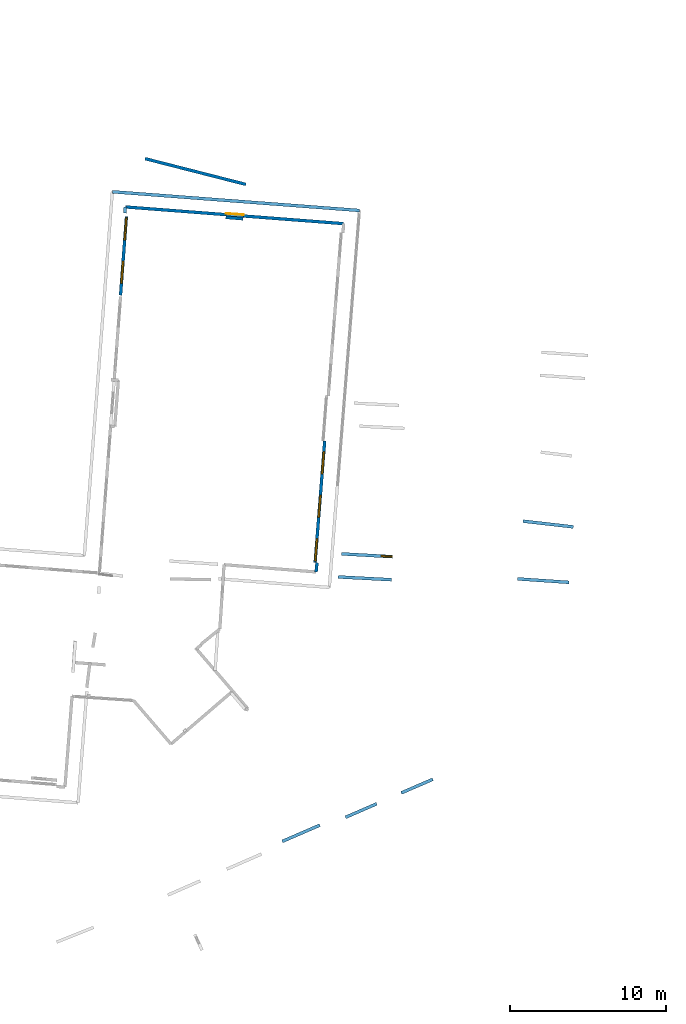
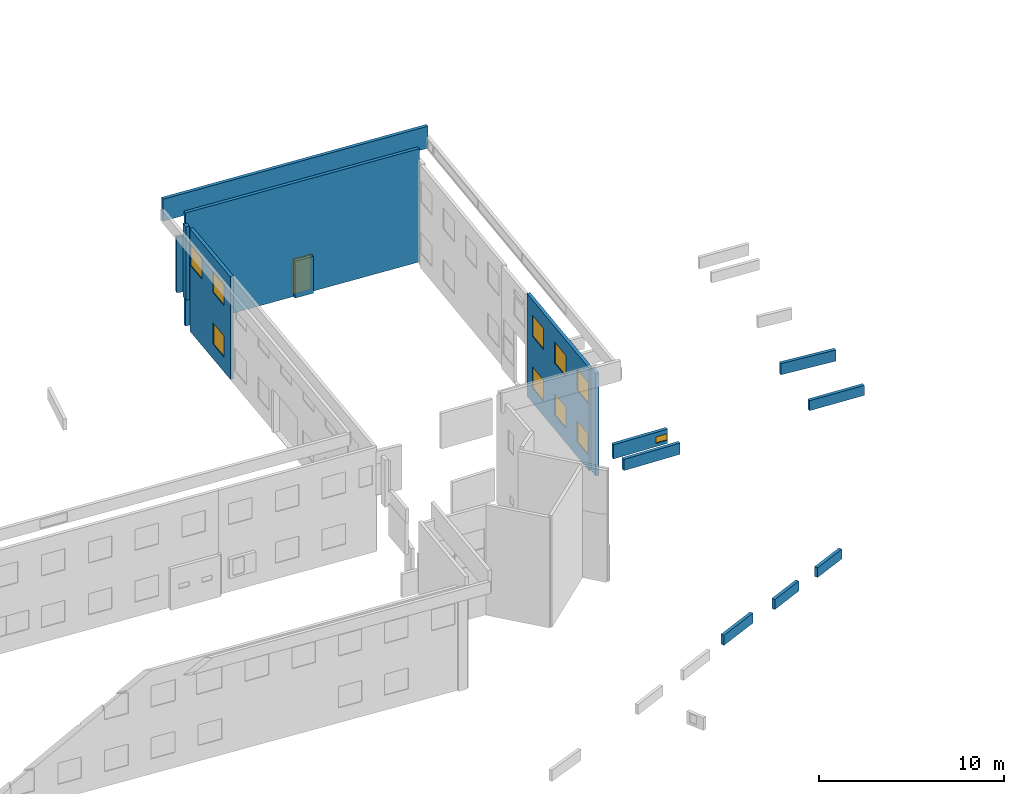
# One storey, part 23 of 27: 15 walls, 10 windows, 1 door, 11 openings.
"""IFC2X3 building model written with IfcOpenShell, lengths in metres."""

from ifc_helpers import new_model, entity, si_unit, converted_unit, derived_unit, direction, frame, frame_2d, origin, origin_2d_with_axis, place, context, subcontext, project, spatial, polyline, rectangle, outline, extrude, source, transform, mapped, material, layer, layer_set, layer_usage, type_object, type_shapes, element, fill, save


model = new_model("IFC2X3")

# Units and contexts
model_context = context("Model", 3, precision=1e-05, world=origin(), true_north=direction((0.0, 1.0)))
body_context = subcontext(model_context, "Body", "Model", "MODEL_VIEW")
ifc_project = project(units=[si_unit("LENGTHUNIT", "METRE"), si_unit("AREAUNIT", "SQUARE_METRE"), si_unit("VOLUMEUNIT", "CUBIC_METRE"), converted_unit("PLANEANGLEUNIT", "DEGREE", entity("IfcRatioMeasure", 0.0174532925199433), si_unit("PLANEANGLEUNIT", "RADIAN"), dimensions=[0, 0, 0, 0, 0, 0, 0]), si_unit("MASSUNIT", "GRAM", prefix="KILO"), derived_unit("MASSDENSITYUNIT", [(si_unit("MASSUNIT", "GRAM", prefix="KILO"), 1), (si_unit("LENGTHUNIT", "METRE"), -3)]), derived_unit("MOMENTOFINERTIAUNIT", [(si_unit("LENGTHUNIT", "METRE"), 4)]), si_unit("TIMEUNIT", "SECOND"), si_unit("FREQUENCYUNIT", "HERTZ"), si_unit("THERMODYNAMICTEMPERATUREUNIT", "DEGREE_CELSIUS"), derived_unit("THERMALTRANSMITTANCEUNIT", [(si_unit("MASSUNIT", "GRAM", prefix="KILO"), 1), (si_unit("THERMODYNAMICTEMPERATUREUNIT", "KELVIN"), -1), (si_unit("TIMEUNIT", "SECOND"), -3)]), derived_unit("VOLUMETRICFLOWRATEUNIT", [(si_unit("LENGTHUNIT", "METRE"), 3), (si_unit("TIMEUNIT", "SECOND"), -1)]), si_unit("ELECTRICCURRENTUNIT", "AMPERE"), si_unit("ELECTRICVOLTAGEUNIT", "VOLT"), si_unit("POWERUNIT", "WATT"), si_unit("FORCEUNIT", "NEWTON", prefix="KILO"), si_unit("ILLUMINANCEUNIT", "LUX"), si_unit("LUMINOUSFLUXUNIT", "LUMEN"), si_unit("LUMINOUSINTENSITYUNIT", "CANDELA"), derived_unit("USERDEFINED", [(si_unit("MASSUNIT", "GRAM", prefix="KILO"), -1), (si_unit("LENGTHUNIT", "METRE"), -2), (si_unit("TIMEUNIT", "SECOND"), 3), (si_unit("LUMINOUSFLUXUNIT", "LUMEN"), 1)]), derived_unit("LINEARVELOCITYUNIT", [(si_unit("LENGTHUNIT", "METRE"), 1), (si_unit("TIMEUNIT", "SECOND"), -1)]), si_unit("PRESSUREUNIT", "PASCAL"), derived_unit("USERDEFINED", [(si_unit("LENGTHUNIT", "METRE"), -2), (si_unit("MASSUNIT", "GRAM", prefix="KILO"), 1), (si_unit("TIMEUNIT", "SECOND"), -2)]), derived_unit("LINEARFORCEUNIT", [(si_unit("MASSUNIT", "GRAM", prefix="KILO"), 1), (si_unit("LENGTHUNIT", "METRE"), 1), (si_unit("TIMEUNIT", "SECOND"), -2), (si_unit("LENGTHUNIT", "METRE"), -1)]), derived_unit("PLANARFORCEUNIT", [(si_unit("MASSUNIT", "GRAM", prefix="KILO"), 1), (si_unit("LENGTHUNIT", "METRE"), 1), (si_unit("TIMEUNIT", "SECOND"), -2), (si_unit("LENGTHUNIT", "METRE"), -2)])], contexts=[model_context])

# Site, building, storey
placement_1 = place(None, origin())
site = spatial("IfcSite", under=ifc_project, at=placement_1, CompositionType="ELEMENT")
building = spatial("IfcBuilding", under=site, at=placement_1, CompositionType="ELEMENT")
storey_placement = place(placement_1, frame((0.0, 0.0, -61.043098449707)))
storey = spatial("IfcBuildingStorey", under=building, at=storey_placement, Name="level_-61.043098", CompositionType="ELEMENT", Elevation=-61.043098449707)

# Walls
ifc_material_1 = material(Name="Default wall")
ifc_layer = layer(ifc_material_1, 0.2)
ifc_layer_set = layer_set([ifc_layer], Name="wall_thickness_0.2000")
ifc_layer_usage = layer_usage(ifc_layer_set, "AXIS2", "POSITIVE", -0.1)
wall_type = type_object("IfcWallType", Name="wall_thickness_0.2000", PredefinedType="STANDARD", material=ifc_layer_set)
wall_1_placement = place(storey_placement, frame((18.2188514308673, -5.39371024535471, 0.0), z_axis=(0.0, 0.0, 1.0), x_axis=(0.0985031111427346, 0.995136742912853, 0.0)))
element("IfcWallStandardCase", 1, at=wall_1_placement, inside=storey, type_object=wall_type, material=ifc_layer_usage, Name="Wall:78", ObjectType="Wall", context=body_context, shape_type="SweptSolid", body=[
    extrude(outline(polyline([(0.596138961269039, -0.1), (0.596138961269039, 0.1), (0.0, 0.1), (0.0, -0.1), (0.596138961269039, -0.1)])), origin(), (0.0, 0.0, 1.0), 6.76219177246094),
])
placement_2 = place(placement_1, frame((0.0, 0.0, -60.9578857421875)))
wall_2_placement = place(placement_2, frame((20.1079442314191, -21.1138243418258, 0.0), z_axis=(0.0, 0.0, 1.0), x_axis=(0.917143584641455, 0.398556953459631, 0.0)))
element("IfcWallStandardCase", 2, at=wall_2_placement, inside=storey, type_object=wall_type, material=ifc_layer_usage, Name="Wall:220", ObjectType="Wall", context=body_context, shape_type="SweptSolid", body=[
    extrude(outline(polyline([(2.17951277879917, -0.1), (2.17951277879917, 0.1), (0.0, 0.1), (0.0, -0.1), (2.17951277879917, -0.1)])), origin(), (0.0, 0.0, 1.0), 0.661750793457031),
])

# Wall, opening, door
wall_3_placement = place(storey_placement, frame((5.99890342957978, 17.9934566983981, 0.0), z_axis=(0.0, 0.0, 1.0), x_axis=(0.997077459882406, -0.0763972446783893, 0.0)))
wall_3 = element("IfcWallStandardCase", 3, at=wall_3_placement, inside=storey, type_object=wall_type, material=ifc_layer_usage, Name="Wall:268", ObjectType="Wall", context=body_context, shape_type="SweptSolid", body=[
    extrude(outline(polyline([(14.0238372089625, -0.1), (14.0238372089625, 0.1), (0.0, 0.1), (0.0, -0.1), (14.0238372089625, -0.1)])), origin(), (0.0, 0.0, 1.0), 7.4647102355957),
])
opening_1_placement = place(wall_3_placement, frame((6.46277733357102, -0.1, 0.037811279296875)))
opening_1 = element("IfcOpeningElement", 4, at=opening_1_placement, cuts=wall_3, Name="Opening : 1140 x 2340 : 16", ObjectType="Opening", context=body_context, shape_type="SweptSolid", body=[
    extrude(rectangle(XDim=1.14, YDim=2.34, at=frame_2d((1.17, 0.57), x_axis=(0.0, 1.0))), frame((0.0, 0.0, 0.0), z_axis=(0.0, 1.0, 0.0), x_axis=(0.0, 0.0, 1.0)), (0.0, 0.0, 1.0), 0.2),
])
ifc_material_2 = material(Name="Door Panel")
door_style = type_object("IfcDoorStyle", Name="Door : 1140 x 2340mm", ConstructionType="NOTDEFINED", OperationType="SINGLE_SWING_RIGHT", ParameterTakesPrecedence=False, Sizeable=False, material=ifc_material_2)
shared_shape_1 = source(origin(), body_context, "Body", "SweptSolid", [
    extrude(rectangle(XDim=0.05, YDim=1.14, at=origin_2d_with_axis()), frame((0.57, 0.175, 0.0), z_axis=(0.0, 0.0, 1.0), x_axis=(0.0, 1.0, 0.0)), (0.0, 0.0, 1.0), 2.34),
])
type_shapes(door_style, [shared_shape_1])
door_placement = place(opening_1_placement, origin())
door = element("IfcDoor", 5, at=door_placement, inside=storey, type_object=door_style, Name="Door : 1140 x 2340mm : 2", ObjectType="Door : 1140 x 2340mm", OverallHeight=2.34, OverallWidth=1.14, context=body_context, shape_type="MappedRepresentation", body=[
    mapped(shared_shape_1, transform((0.0, 0.0, 0.0), scale=1.0)),
])
fill(opening_1, door)

# Wall, openings, windows
wall_4_placement = place(storey_placement, frame((18.7714172781975, 2.99446171995472, 0.0), z_axis=(0.0, 0.0, 1.0), x_axis=(-0.0787013877503453, -0.996898235310992, 0.0)))
wall_4 = element("IfcWallStandardCase", 6, at=wall_4_placement, inside=storey, type_object=wall_type, material=ifc_layer_usage, Name="Wall:297", ObjectType="Wall", context=body_context, shape_type="SweptSolid", body=[
    extrude(outline(polyline([(7.81068516129072, -0.1), (7.81068516129072, 0.1), (0.0, 0.1), (0.0, -0.1), (7.81068516129072, -0.1)])), origin(), (0.0, 0.0, 1.0), 6.76219177246094),
])
opening_2_placement = place(wall_4_placement, frame((0.694999373924037, -0.1, 4.37589645385742)))
opening_2 = element("IfcOpeningElement", 7, at=opening_2_placement, cuts=wall_4, Name="Opening : 1420 x 1390 : 17", ObjectType="Opening", context=body_context, shape_type="SweptSolid", body=[
    extrude(rectangle(XDim=1.42, YDim=1.39, at=frame_2d((0.695, 0.71), x_axis=(0.0, 1.0))), frame((0.0, 0.0, 0.0), z_axis=(0.0, 1.0, 0.0), x_axis=(0.0, 0.0, 1.0)), (0.0, 0.0, 1.0), 0.2),
])
opening_3_placement = place(wall_4_placement, frame((3.48999988778673, -0.1, 4.37089538574219)))
opening_3 = element("IfcOpeningElement", 8, at=opening_3_placement, cuts=wall_4, Name="Opening : 1420 x 1390 : 18", ObjectType="Opening", context=body_context, shape_type="SweptSolid", body=[
    extrude(rectangle(XDim=1.42, YDim=1.39, at=frame_2d((0.695, 0.71), x_axis=(0.0, 1.0))), frame((0.0, 0.0, 0.0), z_axis=(0.0, 1.0, 0.0), x_axis=(0.0, 0.0, 1.0)), (0.0, 0.0, 1.0), 0.2),
])
opening_4_placement = place(wall_4_placement, frame((6.29000000527762, -0.1, 4.36589813232422)))
opening_4 = element("IfcOpeningElement", 9, at=opening_4_placement, cuts=wall_4, Name="Opening : 1420 x 1385 : 19", ObjectType="Opening", context=body_context, shape_type="SweptSolid", body=[
    extrude(rectangle(XDim=1.42, YDim=1.385, at=frame_2d((0.6925, 0.71), x_axis=(0.0, 1.0))), frame((0.0, 0.0, 0.0), z_axis=(0.0, 1.0, 0.0), x_axis=(0.0, 0.0, 1.0)), (0.0, 0.0, 1.0), 0.2),
])
opening_5_placement = place(wall_4_placement, frame((0.689999532616773, -0.1, 0.965896606445312)))
opening_5 = element("IfcOpeningElement", 10, at=opening_5_placement, cuts=wall_4, Name="Opening : 1415 x 1405 : 20", ObjectType="Opening", context=body_context, shape_type="SweptSolid", body=[
    extrude(rectangle(XDim=1.415, YDim=1.405, at=frame_2d((0.7025, 0.7075), x_axis=(0.0, 1.0))), frame((0.0, 0.0, 0.0), z_axis=(0.0, 1.0, 0.0), x_axis=(0.0, 0.0, 1.0)), (0.0, 0.0, 1.0), 0.2),
])
opening_6_placement = place(wall_4_placement, frame((3.48499992763993, -0.1, 0.960899353027344)))
opening_6 = element("IfcOpeningElement", 11, at=opening_6_placement, cuts=wall_4, Name="Opening : 1420 x 1395 : 21", ObjectType="Opening", context=body_context, shape_type="SweptSolid", body=[
    extrude(rectangle(XDim=1.42, YDim=1.395, at=frame_2d((0.6975, 0.71), x_axis=(0.0, 1.0))), frame((0.0, 0.0, 0.0), z_axis=(0.0, 1.0, 0.0), x_axis=(0.0, 0.0, 1.0)), (0.0, 0.0, 1.0), 0.2),
])
opening_7_placement = place(wall_4_placement, frame((6.28500016397035, -0.1, 0.975898742675781)))
opening_7 = element("IfcOpeningElement", 12, at=opening_7_placement, cuts=wall_4, Name="Opening : 1415 x 1375 : 22", ObjectType="Opening", context=body_context, shape_type="SweptSolid", body=[
    extrude(rectangle(XDim=1.415, YDim=1.375, at=frame_2d((0.6875, 0.7075), x_axis=(0.0, 1.0))), frame((0.0, 0.0, 0.0), z_axis=(0.0, 1.0, 0.0), x_axis=(0.0, 0.0, 1.0)), (0.0, 0.0, 1.0), 0.2),
])
ifc_material_3 = material(Name="Window Default")
window_style_1 = type_object("IfcWindowStyle", Name="Window : 1420 x 1385mm", ConstructionType="NOTDEFINED", OperationType="NOTDEFINED", ParameterTakesPrecedence=False, Sizeable=False, material=ifc_material_3)
shared_shape_2 = source(origin(), body_context, "Body", "SweptSolid", [
    extrude(rectangle(XDim=0.1, YDim=1.42, at=origin_2d_with_axis()), frame((0.71, 0.1, 0.0), z_axis=(0.0, 0.0, 1.0), x_axis=(0.0, 1.0, 0.0)), (0.0, 0.0, 1.0), 1.385),
])
type_shapes(window_style_1, [shared_shape_2])
window_1_placement = place(opening_4_placement, origin())
window_1 = element("IfcWindow", 13, at=window_1_placement, inside=storey, type_object=window_style_1, Name="Window : 1420 x 1385mm : 16", ObjectType="Window : 1420 x 1385mm", OverallHeight=1.385, OverallWidth=1.42, context=body_context, shape_type="MappedRepresentation", body=[
    mapped(shared_shape_2, transform((0.0, 0.0, 0.0), scale=1.0)),
])
fill(opening_4, window_1)
window_style_2 = type_object("IfcWindowStyle", Name="Window : 1420 x 1390mm", ConstructionType="NOTDEFINED", OperationType="NOTDEFINED", ParameterTakesPrecedence=False, Sizeable=False, material=ifc_material_3)
shared_shape_3 = source(origin(), body_context, "Body", "SweptSolid", [
    extrude(rectangle(XDim=0.1, YDim=1.42, at=origin_2d_with_axis()), frame((0.71, 0.1, 0.0), z_axis=(0.0, 0.0, 1.0), x_axis=(0.0, 1.0, 0.0)), (0.0, 0.0, 1.0), 1.39),
])
type_shapes(window_style_2, [shared_shape_3])
window_2_placement = place(opening_2_placement, origin())
window_2 = element("IfcWindow", 14, at=window_2_placement, inside=storey, type_object=window_style_2, Name="Window : 1420 x 1390mm : 14", ObjectType="Window : 1420 x 1390mm", OverallHeight=1.39, OverallWidth=1.42, context=body_context, shape_type="MappedRepresentation", body=[
    mapped(shared_shape_3, transform((0.0, 0.0, 0.0), scale=1.0)),
])
fill(opening_2, window_2)
window_3_placement = place(opening_3_placement, origin())
window_3 = element("IfcWindow", 15, at=window_3_placement, inside=storey, type_object=window_style_2, Name="Window : 1420 x 1390mm : 15", ObjectType="Window : 1420 x 1390mm", OverallHeight=1.39, OverallWidth=1.42, context=body_context, shape_type="MappedRepresentation", body=[
    mapped(shared_shape_3, transform((0.0, 0.0, 0.0), scale=1.0)),
])
fill(opening_3, window_3)
window_style_3 = type_object("IfcWindowStyle", Name="Window : 1415 x 1405mm", ConstructionType="NOTDEFINED", OperationType="NOTDEFINED", ParameterTakesPrecedence=False, Sizeable=False, material=ifc_material_3)
shared_shape_4 = source(origin(), body_context, "Body", "SweptSolid", [
    extrude(rectangle(XDim=0.1, YDim=1.415, at=origin_2d_with_axis()), frame((0.7075, 0.1, 0.0), z_axis=(0.0, 0.0, 1.0), x_axis=(0.0, 1.0, 0.0)), (0.0, 0.0, 1.0), 1.405),
])
type_shapes(window_style_3, [shared_shape_4])
window_4_placement = place(opening_5_placement, origin())
window_4 = element("IfcWindow", 16, at=window_4_placement, inside=storey, type_object=window_style_3, Name="Window : 1415 x 1405mm : 17", ObjectType="Window : 1415 x 1405mm", OverallHeight=1.405, OverallWidth=1.415, context=body_context, shape_type="MappedRepresentation", body=[
    mapped(shared_shape_4, transform((0.0, 0.0, 0.0), scale=1.0)),
])
fill(opening_5, window_4)
window_style_4 = type_object("IfcWindowStyle", Name="Window : 1420 x 1395mm", ConstructionType="NOTDEFINED", OperationType="NOTDEFINED", ParameterTakesPrecedence=False, Sizeable=False, material=ifc_material_3)
shared_shape_5 = source(origin(), body_context, "Body", "SweptSolid", [
    extrude(rectangle(XDim=0.1, YDim=1.42, at=origin_2d_with_axis()), frame((0.71, 0.1, 0.0), z_axis=(0.0, 0.0, 1.0), x_axis=(0.0, 1.0, 0.0)), (0.0, 0.0, 1.0), 1.395),
])
type_shapes(window_style_4, [shared_shape_5])
window_5_placement = place(opening_6_placement, origin())
window_5 = element("IfcWindow", 17, at=window_5_placement, inside=storey, type_object=window_style_4, Name="Window : 1420 x 1395mm : 18", ObjectType="Window : 1420 x 1395mm", OverallHeight=1.395, OverallWidth=1.42, context=body_context, shape_type="MappedRepresentation", body=[
    mapped(shared_shape_5, transform((0.0, 0.0, 0.0), scale=1.0)),
])
fill(opening_6, window_5)
window_style_5 = type_object("IfcWindowStyle", Name="Window : 1415 x 1375mm", ConstructionType="NOTDEFINED", OperationType="NOTDEFINED", ParameterTakesPrecedence=False, Sizeable=False, material=ifc_material_3)
shared_shape_6 = source(origin(), body_context, "Body", "SweptSolid", [
    extrude(rectangle(XDim=0.1, YDim=1.415, at=origin_2d_with_axis()), frame((0.7075, 0.1, 0.0), z_axis=(0.0, 0.0, 1.0), x_axis=(0.0, 1.0, 0.0)), (0.0, 0.0, 1.0), 1.375),
])
type_shapes(window_style_5, [shared_shape_6])
window_6_placement = place(opening_7_placement, origin())
window_6 = element("IfcWindow", 18, at=window_6_placement, inside=storey, type_object=window_style_5, Name="Window : 1415 x 1375mm : 19", ObjectType="Window : 1415 x 1375mm", OverallHeight=1.375, OverallWidth=1.415, context=body_context, shape_type="MappedRepresentation", body=[
    mapped(shared_shape_6, transform((0.0, 0.0, 0.0), scale=1.0)),
])
fill(opening_7, window_6)

# Walls
placement_3 = place(placement_1, frame((0.0, 0.0, -60.9578857421875)))
wall_5_placement = place(placement_3, frame((31.484097412767, -2.13897039474531, 0.0), z_axis=(0.0, 0.0, 1.0), x_axis=(0.993494787569292, -0.113877596886514, 0.0)))
element("IfcWallStandardCase", 19, at=wall_5_placement, inside=storey, type_object=wall_type, material=ifc_layer_usage, Name="Wall:329", ObjectType="Wall", context=body_context, shape_type="SweptSolid", body=[
    extrude(outline(polyline([(3.2388427979302, -0.1), (3.2388427979302, 0.1), (0.0, 0.1), (0.0, -0.1), (3.2388427979302, -0.1)])), origin(), (0.0, 0.0, 1.0), 0.739894866943359),
])
placement_4 = place(placement_1, frame((0.0, 0.0, -54.4207000732422)))
wall_6_placement = place(placement_4, frame((5.16797879986426, 18.9660505146065, 0.0), z_axis=(0.0, 0.0, 1.0), x_axis=(0.997136921132578, -0.0756171972122956, 0.0)))
element("IfcWallStandardCase", 20, at=wall_6_placement, inside=storey, type_object=wall_type, material=ifc_layer_usage, Name="Wall:375", ObjectType="Wall", context=body_context, shape_type="SweptSolid", body=[
    extrude(outline(polyline([(15.870778129958, -0.1), (15.870778129958, 0.1), (0.0, 0.1), (0.0, -0.1), (15.870778129958, -0.1)])), origin(), (0.0, 0.0, 1.0), 1.45384979248047),
])
wall_7_placement = place(storey_placement, frame((12.4340048855943, 17.3234335826246, 0.0), z_axis=(0.0, 0.0, 1.0), x_axis=(0.996754720432007, -0.0804986167366321, 0.0)))
element("IfcWallStandardCase", 21, at=wall_7_placement, inside=storey, type_object=wall_type, material=ifc_layer_usage, Name="Wall:515", ObjectType="Wall", context=body_context, shape_type="SweptSolid", body=[
    extrude(outline(polyline([(1.12000014633029, -0.1), (1.12000014633029, 0.1), (0.0, 0.1), (0.0, -0.1), (1.12000014633029, -0.1)])), origin(), (0.0, 0.0, 1.0), 2.43098831176758),
])
placement_5 = place(placement_1, frame((0.0, 0.0, -60.9578857421875)))
wall_8_placement = place(placement_5, frame((19.6365349760471, -5.71251095851869, 0.0), z_axis=(0.0, 0.0, 1.0), x_axis=(0.998626796250092, -0.0523881838898562, 0.0)))
element("IfcWallStandardCase", 22, at=wall_8_placement, inside=storey, type_object=wall_type, material=ifc_layer_usage, Name="Wall:718", ObjectType="Wall", context=body_context, shape_type="SweptSolid", body=[
    extrude(outline(polyline([(3.40999993121128, -0.1), (3.40999993121128, 0.1), (0.0, 0.1), (0.0, -0.1), (3.40999993121128, -0.1)])), origin(), (0.0, 0.0, 1.0), 0.739894866943359),
])
placement_6 = place(placement_1, frame((0.0, 0.0, -60.9578857421875)))
wall_9_placement = place(placement_6, frame((31.1345691987664, -5.83771250655619, 0.0), z_axis=(0.0, 0.0, 1.0), x_axis=(0.997693341801912, -0.0678822194991637, 0.0)))
element("IfcWallStandardCase", 23, at=wall_9_placement, inside=storey, type_object=wall_type, material=ifc_layer_usage, Name="Wall:874", ObjectType="Wall", context=body_context, shape_type="SweptSolid", body=[
    extrude(outline(polyline([(3.28999857014227, -0.1), (3.28999857014227, 0.1), (0.0, 0.1), (0.0, -0.1), (3.28999857014227, -0.1)])), origin(), (0.0, 0.0, 1.0), 0.661750793457031),
])
placement_7 = place(placement_1, frame((0.0, 0.0, -60.9578857421875)))
wall_10_placement = place(placement_7, frame((16.0557855175699, -22.6582108774465, 0.0), z_axis=(0.0, 0.0, 1.0), x_axis=(0.917529189813519, 0.397668437068052, 0.0)))
element("IfcWallStandardCase", 24, at=wall_10_placement, inside=storey, type_object=wall_type, material=ifc_layer_usage, Name="Wall:1023", ObjectType="Wall", context=body_context, shape_type="SweptSolid", body=[
    extrude(outline(polyline([(2.61930401152871, -0.1), (2.61930401152871, 0.1), (0.0, 0.1), (0.0, -0.1), (2.61930401152871, -0.1)])), origin(), (0.0, 0.0, 1.0), 0.661750793457031),
])

# Wall, opening, window
placement_8 = place(placement_1, frame((0.0, 0.0, -61.1552200317383)))
wall_11_placement = place(placement_8, frame((19.840714811894, -4.23321768663211, 0.0), z_axis=(0.0, 0.0, 1.0), x_axis=(0.998434726464552, -0.0559293928954667, 0.0)))
wall_11 = element("IfcWallStandardCase", 25, at=wall_11_placement, inside=storey, type_object=wall_type, material=ifc_layer_usage, Name="Wall:1081", ObjectType="Wall", context=body_context, shape_type="SweptSolid", body=[
    extrude(outline(polyline([(3.28322103291475, -0.1), (3.28322103291475, 0.1), (0.0, 0.1), (0.0, -0.1), (3.28322103291475, -0.1)])), origin(), (0.0, 0.0, 1.0), 0.937229156494141),
])
opening_8_placement = place(wall_11_placement, frame((2.56500049160134, -0.1, 0.217395782470703)))
opening_8 = element("IfcOpeningElement", 26, at=opening_8_placement, cuts=wall_11, Name="Opening : 705 x 420 : 135", ObjectType="Opening", context=body_context, shape_type="SweptSolid", body=[
    extrude(rectangle(XDim=0.705, YDim=0.42, at=frame_2d((0.21, 0.3525), x_axis=(0.0, 1.0))), frame((0.0, 0.0, 0.0), z_axis=(0.0, 1.0, 0.0), x_axis=(0.0, 0.0, 1.0)), (0.0, 0.0, 1.0), 0.2),
])
window_style_6 = type_object("IfcWindowStyle", Name="Window : 705 x 420mm", ConstructionType="NOTDEFINED", OperationType="NOTDEFINED", ParameterTakesPrecedence=False, Sizeable=False, material=ifc_material_3)
shared_shape_7 = source(origin(), body_context, "Body", "SweptSolid", [
    extrude(rectangle(XDim=0.1, YDim=0.705, at=origin_2d_with_axis()), frame((0.3525, 0.1, 0.0), z_axis=(0.0, 0.0, 1.0), x_axis=(0.0, 1.0, 0.0)), (0.0, 0.0, 1.0), 0.42),
])
type_shapes(window_style_6, [shared_shape_7])
window_7_placement = place(opening_8_placement, origin())
window_7 = element("IfcWindow", 27, at=window_7_placement, inside=storey, type_object=window_style_6, Name="Window : 705 x 420mm : 122", ObjectType="Window : 705 x 420mm", OverallHeight=0.42, OverallWidth=0.705, context=body_context, shape_type="MappedRepresentation", body=[
    mapped(shared_shape_7, transform((0.0, 0.0, 0.0), scale=1.0)),
])
fill(opening_8, window_7)

# Wall, openings, windows
wall_12_placement = place(storey_placement, frame((6.06977201759803, 17.3748788028507, 0.0), z_axis=(0.0, 0.0, 1.0), x_axis=(-0.075064401332842, -0.99717868792536, 0.0)))
wall_12 = element("IfcWallStandardCase", 28, at=wall_12_placement, inside=storey, type_object=wall_type, material=ifc_layer_usage, Name="Wall:1499", ObjectType="Wall", context=body_context, shape_type="SweptSolid", body=[
    extrude(outline(polyline([(5.05499696873614, -0.1), (5.05499696873614, 0.1), (0.0, 0.1), (0.0, -0.1), (5.05499696873614, -0.1)])), origin(), (0.0, 0.0, 1.0), 6.76219177246094),
])
opening_9_placement = place(wall_12_placement, frame((0.0749987090901685, -0.1, 4.37073135375977)))
opening_9 = element("IfcOpeningElement", 29, at=opening_9_placement, cuts=wall_12, Name="Opening : 1430 x 1395 : 235", ObjectType="Opening", context=body_context, shape_type="SweptSolid", body=[
    extrude(rectangle(XDim=1.43, YDim=1.395, at=frame_2d((0.6975, 0.715), x_axis=(0.0, 1.0))), frame((0.0, 0.0, 0.0), z_axis=(0.0, 1.0, 0.0), x_axis=(0.0, 0.0, 1.0)), (0.0, 0.0, 1.0), 0.2),
])
opening_10_placement = place(wall_12_placement, frame((2.87999729486219, -0.1, 4.37073135375977)))
opening_10 = element("IfcOpeningElement", 30, at=opening_10_placement, cuts=wall_12, Name="Opening : 1405 x 1395 : 236", ObjectType="Opening", context=body_context, shape_type="SweptSolid", body=[
    extrude(rectangle(XDim=1.405, YDim=1.395, at=frame_2d((0.6975, 0.7025), x_axis=(0.0, 1.0))), frame((0.0, 0.0, 0.0), z_axis=(0.0, 1.0, 0.0), x_axis=(0.0, 0.0, 1.0)), (0.0, 0.0, 1.0), 0.2),
])
opening_11_placement = place(wall_12_placement, frame((2.88999715522233, -0.1, 0.970733642578125)))
opening_11 = element("IfcOpeningElement", 31, at=opening_11_placement, cuts=wall_12, Name="Opening : 1400 x 1400 : 237", ObjectType="Opening", context=body_context, shape_type="SweptSolid", body=[
    extrude(rectangle(XDim=1.4, YDim=1.4, at=frame_2d((0.7, 0.7), x_axis=(0.0, 1.0))), frame((0.0, 0.0, 0.0), z_axis=(0.0, 1.0, 0.0), x_axis=(0.0, 0.0, 1.0)), (0.0, 0.0, 1.0), 0.2),
])
window_style_7 = type_object("IfcWindowStyle", Name="Window : 1405 x 1395mm", ConstructionType="NOTDEFINED", OperationType="NOTDEFINED", ParameterTakesPrecedence=False, Sizeable=False, material=ifc_material_3)
shared_shape_8 = source(origin(), body_context, "Body", "SweptSolid", [
    extrude(rectangle(XDim=0.1, YDim=1.405, at=origin_2d_with_axis()), frame((0.7025, 0.1, 0.0), z_axis=(0.0, 0.0, 1.0), x_axis=(0.0, 1.0, 0.0)), (0.0, 0.0, 1.0), 1.395),
])
type_shapes(window_style_7, [shared_shape_8])
window_8_placement = place(opening_10_placement, origin())
window_8 = element("IfcWindow", 32, at=window_8_placement, inside=storey, type_object=window_style_7, Name="Window : 1405 x 1395mm : 219", ObjectType="Window : 1405 x 1395mm", OverallHeight=1.395, OverallWidth=1.405, context=body_context, shape_type="MappedRepresentation", body=[
    mapped(shared_shape_8, transform((0.0, 0.0, 0.0), scale=1.0)),
])
fill(opening_10, window_8)
window_style_8 = type_object("IfcWindowStyle", Name="Window : 1430 x 1395mm", ConstructionType="NOTDEFINED", OperationType="NOTDEFINED", ParameterTakesPrecedence=False, Sizeable=False, material=ifc_material_3)
shared_shape_9 = source(origin(), body_context, "Body", "SweptSolid", [
    extrude(rectangle(XDim=0.1, YDim=1.43, at=origin_2d_with_axis()), frame((0.715, 0.1, 0.0), z_axis=(0.0, 0.0, 1.0), x_axis=(0.0, 1.0, 0.0)), (0.0, 0.0, 1.0), 1.395),
])
type_shapes(window_style_8, [shared_shape_9])
window_9_placement = place(opening_9_placement, origin())
window_9 = element("IfcWindow", 33, at=window_9_placement, inside=storey, type_object=window_style_8, Name="Window : 1430 x 1395mm : 218", ObjectType="Window : 1430 x 1395mm", OverallHeight=1.395, OverallWidth=1.43, context=body_context, shape_type="MappedRepresentation", body=[
    mapped(shared_shape_9, transform((0.0, 0.0, 0.0), scale=1.0)),
])
fill(opening_9, window_9)
window_style_9 = type_object("IfcWindowStyle", Name="Window : 1400 x 1400mm", ConstructionType="NOTDEFINED", OperationType="NOTDEFINED", ParameterTakesPrecedence=False, Sizeable=False, material=ifc_material_3)
shared_shape_10 = source(origin(), body_context, "Body", "SweptSolid", [
    extrude(rectangle(XDim=0.1, YDim=1.4, at=origin_2d_with_axis()), frame((0.7, 0.1, 0.0), z_axis=(0.0, 0.0, 1.0), x_axis=(0.0, 1.0, 0.0)), (0.0, 0.0, 1.0), 1.4),
])
type_shapes(window_style_9, [shared_shape_10])
window_10_placement = place(opening_11_placement, origin())
window_10 = element("IfcWindow", 34, at=window_10_placement, inside=storey, type_object=window_style_9, Name="Window : 1400 x 1400mm : 220", ObjectType="Window : 1400 x 1400mm", OverallHeight=1.4, OverallWidth=1.4, context=body_context, shape_type="MappedRepresentation", body=[
    mapped(shared_shape_10, transform((0.0, 0.0, 0.0), scale=1.0)),
])
fill(opening_11, window_10)

# Walls
wall_13_placement = place(storey_placement, frame((23.6804352197132, -19.5494920966759, 0.0), z_axis=(0.0, 0.0, 1.0), x_axis=(0.917894539055043, 0.396824413529373, 0.0)))
element("IfcWallStandardCase", 35, at=wall_13_placement, inside=storey, type_object=wall_type, material=ifc_layer_usage, Name="Wall:1590", ObjectType="Wall", context=body_context, shape_type="SweptSolid", body=[
    extrude(outline(polyline([(2.1995981170233, -0.1), (2.1995981170233, 0.1), (0.0, 0.1), (0.0, -0.1), (2.1995981170233, -0.1)])), origin(), (0.0, 0.0, 1.0), 0.645053863525391),
])
placement_9 = place(placement_1, frame((0.0, 0.0, -59.1070327758789)))
wall_14_placement = place(placement_9, frame((5.97037476313619, 17.5936365902335, 0.0), z_axis=(0.0, 0.0, 1.0), x_axis=(0.0711719775549456, 0.997464059307862, 0.0)))
element("IfcWallStandardCase", 36, at=wall_14_placement, inside=storey, type_object=wall_type, material=ifc_layer_usage, Name="Wall:1854", ObjectType="Wall", context=body_context, shape_type="SweptSolid", body=[
    extrude(outline(polyline([(0.400834913979346, -0.1), (0.400834913979346, 0.1), (0.0, 0.1), (0.0, -0.1), (0.400834913979346, -0.1)])), origin(), (0.0, 0.0, 1.0), 4.82612609863281),
])
placement_10 = place(placement_1, frame((0.0, 0.0, -61.1552200317383)))
wall_15_placement = place(placement_10, frame((7.26343357873724, 21.0868627314762, 0.0), z_axis=(0.0, 0.0, 1.0), x_axis=(0.968874211853261, -0.247553553005651, 0.0)))
element("IfcWallStandardCase", 37, at=wall_15_placement, inside=storey, type_object=wall_type, material=ifc_layer_usage, Name="Wall:1868", ObjectType="Wall", context=body_context, shape_type="SweptSolid", body=[
    extrude(outline(polyline([(6.66999990359631, -0.1), (6.66999990359631, 0.1), (0.0, 0.1), (0.0, -0.1), (6.66999990359631, -0.1)])), origin(), (0.0, 0.0, 1.0), 3.65055847167969),
])

save(model, "model.ifc")
